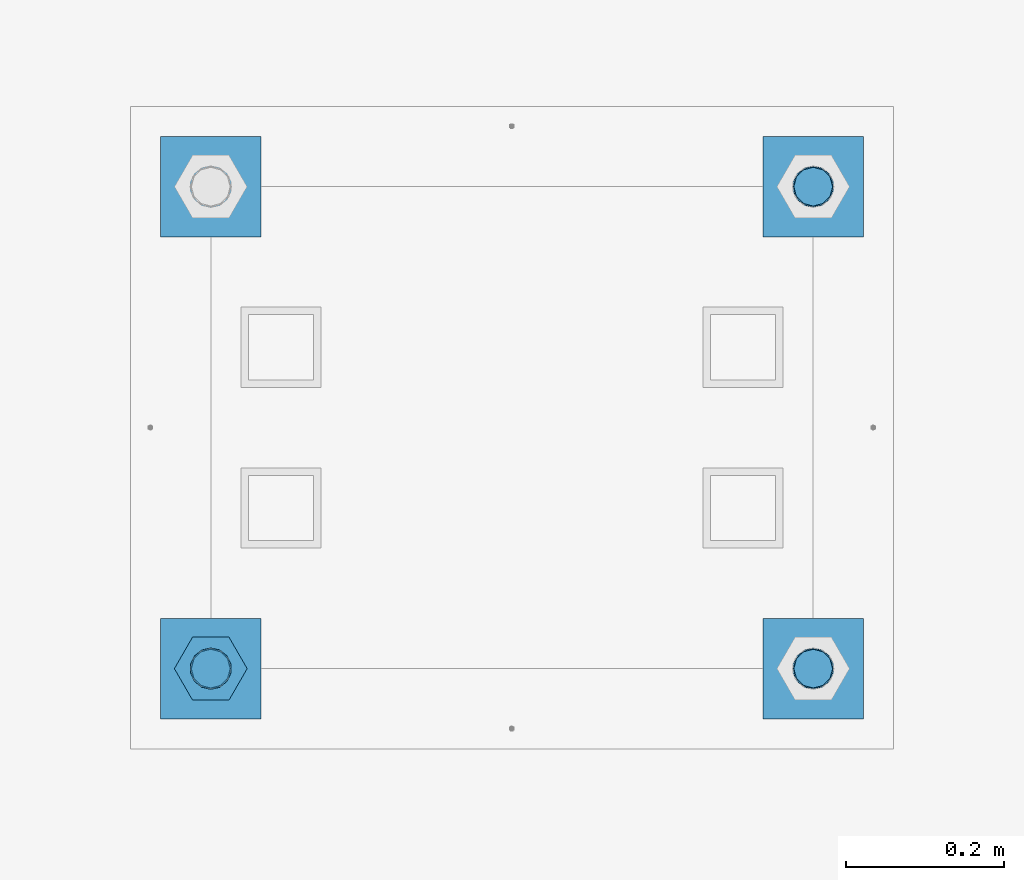
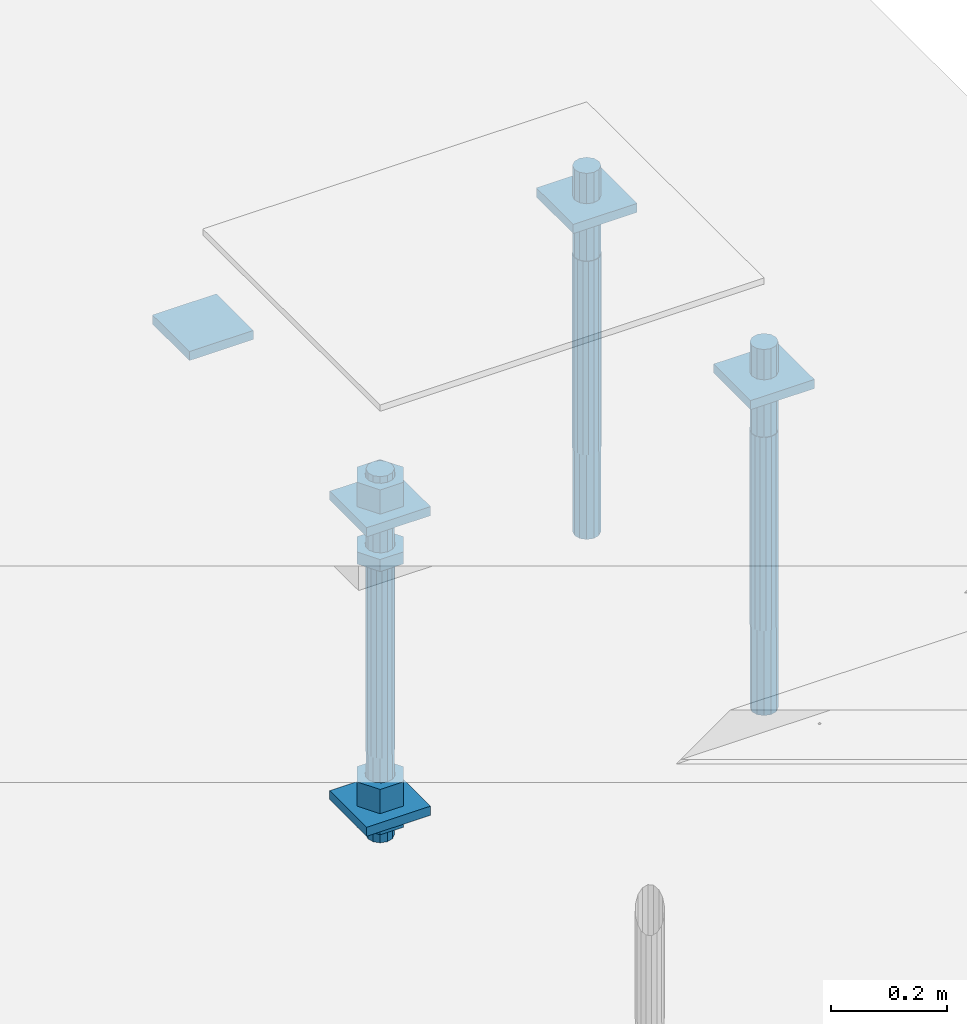
# One storey, part 2634 of 3843: 12 beams, 1 element without a shape of its own.
"""IFC2X3 building model written with IfcOpenShell, lengths in millimetres."""

import ifcopenshell
import ifcopenshell.guid

model = None  # the IFC model being written
_history = None  # IfcOwnerHistory: only IFC2X3 demands one
_inside = {}  # id of a spatial element -> (the spatial element, [elements in it])
_under = {}  # id of a project, library or spatial element -> (it, [spatial elements below it])
_declared = {}  # id of a project -> (the project, [libraries it declares])
_typed = {}  # id of a type object -> (the type object, [elements of that type])
_made_of = {}  # id of a material, layer set ... -> (it, [elements and type objects made of it])


def new_model(schema):
    """Start an empty IFC model of exactly this schema.

    Asked for "IFC4X3", IfcOpenShell would pick the latest addendum, in which some entities
    have other attributes; the version numbers below select the first issue.
    IFC2X3 requires an IfcOwnerHistory on every rooted entity: one is made here for all.
    """
    global model, _history
    if schema == "IFC4X3":
        model = ifcopenshell.file(schema_version=(4, 3, 0, 0))
    else:
        model = ifcopenshell.file(schema=schema)
    _inside.clear()
    _under.clear()
    _declared.clear()
    _typed.clear()
    _made_of.clear()
    _history = None
    if model.schema == "IFC2X3":
        org = make("IfcOrganization", Name="unknown")
        user = make(
            "IfcPersonAndOrganization",
            ThePerson=make("IfcPerson", FamilyName="unknown"),
            TheOrganization=org,
        )
        app = make(
            "IfcApplication",
            ApplicationDeveloper=org,
            Version="unknown",
            ApplicationFullName="unknown",
            ApplicationIdentifier="unknown",
        )
        _history = make(
            "IfcOwnerHistory",
            OwningUser=user,
            OwningApplication=app,
            ChangeAction="ADDED",
            CreationDate=0,
        )
    return model


def make(cls, **values):
    """One entity of the class cls with the attributes given. An attribute that is None is left unset."""
    return model.create_entity(
        cls, **{name: value for name, value in values.items() if value is not None}
    )


def rooted(cls, **values):
    """An entity with a GlobalId (a new one), such as an element, a storey or a relation."""
    return make(cls, GlobalId=ifcopenshell.guid.new(), OwnerHistory=_history, **values)


def si_unit(unit_type, name, prefix=None):
    """IfcSIUnit, for example si_unit("LENGTHUNIT", "METRE", prefix="MILLI")."""
    return make("IfcSIUnit", UnitType=unit_type, Prefix=prefix, Name=name)


def assignment(units):
    """IfcUnitAssignment: the units of a project."""
    return None if units is None else make("IfcUnitAssignment", Units=units)


def point(xyz):
    """IfcCartesianPoint."""
    return None if xyz is None else make("IfcCartesianPoint", Coordinates=xyz)


def direction(xyz):
    """IfcDirection."""
    return None if xyz is None else make("IfcDirection", DirectionRatios=xyz)


def frame(location, z_axis=None, x_axis=None):
    """IfcAxis2Placement3D, a coordinate frame: its origin and axes. An axis left out is left unset."""
    return make(
        "IfcAxis2Placement3D",
        Location=point(location),
        Axis=direction(z_axis),
        RefDirection=direction(x_axis),
    )


def origin_with_axes():
    """The frame at (0, 0, 0) with the z axis (0, 0, 1) and the x axis (1, 0, 0) written out."""
    return frame((0.0, 0.0, 0.0), z_axis=(0.0, 0.0, 1.0), x_axis=(1.0, 0.0, 0.0))


def place(relative_to, where):
    """IfcLocalPlacement: puts the frame where relative to a parent placement (None: the world)."""
    return make(
        "IfcLocalPlacement", PlacementRelTo=relative_to, RelativePlacement=where
    )


def context(
    kind, dimensions, precision=None, world=None, true_north=None, identifier=None
):
    """IfcGeometricRepresentationContext, for example the 3D "Model" context."""
    return make(
        "IfcGeometricRepresentationContext",
        ContextIdentifier=identifier,
        ContextType=kind,
        CoordinateSpaceDimension=dimensions,
        Precision=precision,
        WorldCoordinateSystem=world,
        TrueNorth=true_north,
    )


def subcontext(parent, identifier, kind, view, scale=None):
    """IfcGeometricRepresentationSubContext, for example "Body" below "Model"."""
    return make(
        "IfcGeometricRepresentationSubContext",
        ContextIdentifier=identifier,
        ContextType=kind,
        ParentContext=parent,
        TargetScale=scale,
        TargetView=view,
    )


def project(units=None, contexts=None):
    """IfcProject with its units and contexts."""
    return rooted(
        "IfcProject",
        Name="project",
        RepresentationContexts=contexts,
        UnitsInContext=assignment(units),
    )


def spatial(cls, under=None, at=None, **own):
    """A site, building, storey or space (cls), placed at a placement, below another one or the project."""
    s = rooted(cls, ObjectPlacement=at, **own)
    if under is not None:
        _under.setdefault(under.id(), (under, []))[1].append(s)
    return s


def faces_of(points, faces, orient=None, outer=None):
    """IfcFace entities. A face is a list of loops; a loop is a list of indices into points, from 0.

    orient and outer hold one flag for each loop. By default every Orientation is true, the
    first loop of a face is its IfcFaceOuterBound and the others are IfcFaceBound.
    """
    made = []
    for i, loops in enumerate(faces):
        bounds = []
        for j, loop in enumerate(loops):
            is_outer = j == 0 if outer is None else outer[i][j]
            bounds.append(
                make(
                    "IfcFaceOuterBound" if is_outer else "IfcFaceBound",
                    Bound=make("IfcPolyLoop", Polygon=[points[k] for k in loop]),
                    Orientation=True if orient is None else orient[i][j],
                )
            )
        made.append(make("IfcFace", Bounds=bounds))
    return made


def faceted_brep(points, faces, orient=None, outer=None, voids=None):
    """IfcFacetedBrep: a solid bounded by flat faces; with voids (closed shells), ...WithVoids."""
    shared = [point(p) for p in points]
    hull = make("IfcClosedShell", CfsFaces=faces_of(shared, faces, orient, outer))
    if voids is None:
        return make("IfcFacetedBrep", Outer=hull)
    return make(
        "IfcFacetedBrepWithVoids",
        Outer=hull,
        Voids=[
            make(cls, CfsFaces=faces_of(shared, fs, o, b)) for cls, fs, o, b in voids
        ],
    )


def shape(context_of_items, identifier, shape_type, items):
    """IfcShapeRepresentation: the items that make up one representation, for example the "Body"."""
    return make(
        "IfcShapeRepresentation",
        ContextOfItems=context_of_items,
        RepresentationIdentifier=identifier,
        RepresentationType=shape_type,
        Items=items,
    )


def material(Name=None, Category=None):
    """IfcMaterial."""
    return make("IfcMaterial", Name=Name, Category=Category)


def made_of(thing, what):
    """Note that an element or type object is made of a material, layer set ...; save() writes the relation."""
    if what is not None:
        _made_of.setdefault(what.id(), (what, []))[1].append(thing)
    return thing


def type_object(cls, material=None, **own):
    """A type object (cls), such as IfcWallType, which elements share."""
    return made_of(rooted(cls, **own), material)


def element(
    cls,
    number,
    at=None,
    inside=None,
    cuts=None,
    type_object=None,
    material=None,
    context=None,
    identifier="Body",
    shape_type=None,
    held_by="IfcProductDefinitionShape",
    body=None,
    shapes=None,
    **own,
):
    """One element of the class cls, such as IfcWall. Its Tag is "e" and its number.

    at: its placement. inside: the storey or other place that contains it. cuts: it is an
    opening in that element (IfcRelVoidsElement). A single representation is given by context,
    identifier, shape_type and body (its items); several are given by shapes. held_by: the class
    of the entity that holds the representations. save() writes the other relations.
    """
    e = rooted(cls, Tag="e%d" % number, ObjectPlacement=at, **own)
    if body is not None:
        shapes = [shape(context, identifier, shape_type, body)]
    if shapes is not None:
        e.Representation = make(held_by, Representations=shapes)
    if inside is not None:
        _inside.setdefault(inside.id(), (inside, []))[1].append(e)
    if cuts is not None:
        rooted(
            "IfcRelVoidsElement", RelatingBuildingElement=cuts, RelatedOpeningElement=e
        )
    if type_object is not None:
        _typed.setdefault(type_object.id(), (type_object, []))[1].append(e)
    return made_of(e, material)


def aggregate(whole, parts):
    """IfcRelAggregates: a whole, such as a stair, and the parts it consists of."""
    return rooted("IfcRelAggregates", RelatingObject=whole, RelatedObjects=parts)


def save(model, path):
    """Write the relations noted so far, then the file.

    IfcRelAggregates (storeys below a building ...), IfcRelContainedInSpatialStructure (elements
    in a storey), IfcRelDefinesByType, IfcRelAssociatesMaterial and IfcRelDeclares: one each for
    every whole, place, type object, material and project.
    """
    for whole, parts in _under.values():
        aggregate(whole, parts)
    for where, things in _inside.values():
        rooted(
            "IfcRelContainedInSpatialStructure",
            RelatedElements=things,
            RelatingStructure=where,
        )
    for kind, things in _typed.values():
        rooted("IfcRelDefinesByType", RelatedObjects=things, RelatingType=kind)
    for what, things in _made_of.values():
        rooted("IfcRelAssociatesMaterial", RelatedObjects=things, RelatingMaterial=what)
    for by, libraries in _declared.values():
        rooted("IfcRelDeclares", RelatingContext=by, RelatedDefinitions=libraries)
    model.write(path)


model = new_model("IFC2X3")

# Units and contexts
model_context = context("Model", 3, precision=1e-05, world=origin_with_axes())
body_context = subcontext(model_context, "Body", "Model", "MODEL_VIEW")
ifc_project = project(units=[si_unit("LENGTHUNIT", "METRE", prefix="MILLI"), si_unit("AREAUNIT", "SQUARE_METRE"), si_unit("VOLUMEUNIT", "CUBIC_METRE"), si_unit("MASSUNIT", "GRAM", prefix="KILO"), si_unit("TIMEUNIT", "SECOND"), si_unit("PLANEANGLEUNIT", "RADIAN"), si_unit("SOLIDANGLEUNIT", "STERADIAN"), si_unit("THERMODYNAMICTEMPERATUREUNIT", "DEGREE_CELSIUS"), si_unit("LUMINOUSINTENSITYUNIT", "LUMEN")], contexts=[model_context])

# Site, building, storey
site_placement = place(None, origin_with_axes())
site = spatial("IfcSite", under=ifc_project, at=site_placement, CompositionType="ELEMENT")
building_placement = place(site_placement, origin_with_axes())
building = spatial("IfcBuilding", under=site, at=building_placement, Name="Undefined", CompositionType="ELEMENT")
storey_placement = place(building_placement, origin_with_axes())
storey = spatial("IfcBuildingStorey", under=building, at=storey_placement, Name="Undefined", CompositionType="ELEMENT", Elevation=0.0)

# Assembly, beams
assembly_placement = place(storey_placement, origin_with_axes())
assembly = element("IfcElementAssembly", 1, at=assembly_placement, inside=storey, Name="TEMPLATE", AssemblyPlace="NOTDEFINED", PredefinedType="RIGID_FRAME")
ifc_material_1 = material(Name="STEEL/A572-50")
beam_type_1 = type_object("IfcBeamType", PredefinedType="NOTDEFINED")
beam_1_placement = place(assembly_placement, frame((118465.6, 2819.40000152587, 29873.575), z_axis=(1.0, 0.0, 0.0), x_axis=(0.0, 1.0, 0.0)))
beam_1 = element("IfcBeam", 2, at=beam_1_placement, type_object=beam_type_1, material=ifc_material_1, Name="WASHER_PLATE", context=body_context, shape_type="Brep", body=[
    faceted_brep([(0.0, 9.52500000000146, -63.5), (0.0, 9.52500000000146, 63.5), (127.0, 9.52500000000146, 63.5), (127.0, 9.52500000000146, -63.5), (0.0, -9.52500000000146, 63.5), (127.0, -9.52500000000146, 63.5), (0.0, -9.52500000000146, -63.5), (127.0, -9.52500000000146, -63.5)], [[[0, 1, 2, 3]], [[1, 4, 5, 2]], [[4, 6, 7, 5]], [[6, 0, 3, 7]], [[5, 7, 3, 2]], [[6, 4, 1, 0]]]),
])
beam_2_placement = place(assembly_placement, frame((119227.6, 2819.40000152587, 29873.575), z_axis=(1.0, 0.0, 0.0), x_axis=(0.0, 1.0, 0.0)))
beam_2 = element("IfcBeam", 3, at=beam_2_placement, type_object=beam_type_1, material=ifc_material_1, Name="WASHER_PLATE", context=body_context, shape_type="Brep", body=[
    faceted_brep([(0.0, 9.52500000000146, -63.5), (0.0, 9.52500000000146, 63.5), (127.0, 9.52500000000146, 63.5), (127.0, 9.52500000000146, -63.5), (0.0, -9.52500000000146, 63.5), (127.0, -9.52500000000146, 63.5), (0.0, -9.52500000000146, -63.5), (127.0, -9.52500000000146, -63.5)], [[[0, 1, 2, 3]], [[1, 4, 5, 2]], [[4, 6, 7, 5]], [[6, 0, 3, 7]], [[5, 7, 3, 2]], [[6, 4, 1, 0]]]),
])
beam_3_placement = place(assembly_placement, frame((118465.6, 3429.00000152587, 29873.575), z_axis=(1.0, 0.0, 0.0), x_axis=(0.0, 1.0, 0.0)))
beam_3 = element("IfcBeam", 4, at=beam_3_placement, type_object=beam_type_1, material=ifc_material_1, Name="WASHER_PLATE", context=body_context, shape_type="Brep", body=[
    faceted_brep([(0.0, 9.52500000000146, -63.5), (0.0, 9.52500000000146, 63.5), (127.0, 9.52500000000146, 63.5), (127.0, 9.52500000000146, -63.5), (0.0, -9.52500000000146, 63.5), (127.0, -9.52500000000146, 63.5), (0.0, -9.52500000000146, -63.5), (127.0, -9.52500000000146, -63.5)], [[[0, 1, 2, 3]], [[1, 4, 5, 2]], [[4, 6, 7, 5]], [[6, 0, 3, 7]], [[5, 7, 3, 2]], [[6, 4, 1, 0]]]),
])
beam_4_placement = place(assembly_placement, frame((119227.6, 3429.00000152587, 29873.575), z_axis=(1.0, 0.0, 0.0), x_axis=(0.0, 1.0, 0.0)))
beam_4 = element("IfcBeam", 5, at=beam_4_placement, type_object=beam_type_1, material=ifc_material_1, Name="WASHER_PLATE", context=body_context, shape_type="Brep", body=[
    faceted_brep([(0.0, 9.52500000000146, -63.5), (0.0, 9.52500000000146, 63.5), (127.0, 9.52500000000146, 63.5), (127.0, 9.52500000000146, -63.5), (0.0, -9.52500000000146, 63.5), (127.0, -9.52500000000146, 63.5), (0.0, -9.52500000000146, -63.5), (127.0, -9.52500000000146, -63.5)], [[[0, 1, 2, 3]], [[1, 4, 5, 2]], [[4, 6, 7, 5]], [[6, 0, 3, 7]], [[5, 7, 3, 2]], [[6, 4, 1, 0]]]),
])
beam_5_placement = place(assembly_placement, frame((118465.6, 2819.40000152587, 29244.925), z_axis=(1.0, 0.0, 0.0), x_axis=(0.0, 1.0, 0.0)))
beam_5 = element("IfcBeam", 6, at=beam_5_placement, type_object=beam_type_1, material=ifc_material_1, Name="WASHER_PLATE", context=body_context, shape_type="Brep", body=[
    faceted_brep([(0.0, 9.52500000000146, -63.5), (0.0, 9.52500000000146, 63.5), (127.0, 9.52500000000146, 63.5), (127.0, 9.52500000000146, -63.5), (0.0, -9.52500000000146, 63.5), (127.0, -9.52500000000146, 63.5), (0.0, -9.52500000000146, -63.5), (127.0, -9.52500000000146, -63.5)], [[[0, 1, 2, 3]], [[1, 4, 5, 2]], [[4, 6, 7, 5]], [[6, 0, 3, 7]], [[5, 7, 3, 2]], [[6, 4, 1, 0]]]),
])
ifc_material_2 = material(Name="STEEL/A36")
beam_type_2 = type_object("IfcBeamType", Name="2_HALF_NUT", PredefinedType="NOTDEFINED")
beam_6_placement = place(assembly_placement, frame((118465.6, 2882.90000152587, 29787.85), z_axis=(0.0, 1.0, 0.0), x_axis=(0.0, 0.0, -1.0)))
beam_6 = element("IfcBeam", 7, at=beam_6_placement, type_object=beam_type_2, material=ifc_material_2, Name="NUT", ObjectType="2_HALF_NUT", context=body_context, shape_type="Brep", body=[
    faceted_brep([(0.0, -46.0369987487793, 0.0), (0.0, -23.0184993743896, -39.869213104248), (25.4000000000015, -23.0184993743896, -39.869213104248), (25.4000000000015, -46.0369987487793, 0.0), (0.0, 23.0184993743896, -39.869213104248), (25.4000000000015, 23.0184993743896, -39.869213104248), (0.0, 46.0369987487793, 0.0), (25.4000000000015, 46.0369987487793, 0.0), (0.0, 23.0184993743896, 39.869213104248), (25.4000000000015, 23.0184993743896, 39.869213104248), (0.0, -23.0184993743896, 39.869213104248), (25.4000000000015, -23.0184993743896, 39.869213104248), (0.0, 0.0, 26.1940002441406), (0.0, 11.3650617044477, 23.5999013092805), (25.4000000000015, 11.3650617044477, 23.5999013092805), (25.4000000000015, 0.0, 26.1940002441406), (0.0, 20.4791109456419, 16.3316083006721), (25.4000000000015, 20.4791109456419, 16.3316083006721), (0.0, 25.5370200498292, 5.82867859874386), (25.4000000000015, 25.5370200498292, 5.82867859874386), (0.0, 25.5370200498292, -5.82867859874386), (25.4000000000015, 25.5370200498292, -5.82867859874386), (0.0, 20.4791109456419, -16.3316083006721), (25.4000000000015, 20.4791109456419, -16.3316083006721), (0.0, 11.3650617044477, -23.5999013092805), (25.4000000000015, 11.3650617044477, -23.5999013092805), (0.0, 0.0, -26.1940002441406), (25.4000000000015, 0.0, -26.1940002441406), (0.0, -11.3650617044477, -23.5999013092805), (25.4000000000015, -11.3650617044477, -23.5999013092805), (0.0, -20.4791109456419, -16.3316083006721), (25.4000000000015, -20.4791109456419, -16.3316083006721), (0.0, -25.5370200498292, -5.82867859874386), (25.4000000000015, -25.5370200498292, -5.82867859874386), (0.0, -25.5370200498292, 5.82867859874386), (25.4000000000015, -25.5370200498292, 5.82867859874386), (0.0, -20.4791109456419, 16.3316083006721), (25.4000000000015, -20.4791109456419, 16.3316083006721), (0.0, -11.3650617044477, 23.5999013092805), (25.4000000000015, -11.3650617044477, 23.5999013092805)], [[[0, 1, 2, 3]], [[1, 4, 5, 2]], [[4, 6, 7, 5]], [[6, 8, 9, 7]], [[8, 10, 11, 9]], [[10, 0, 3, 11]], [[12, 13, 14, 15]], [[13, 16, 17, 14]], [[16, 18, 19, 17]], [[18, 20, 21, 19]], [[20, 22, 23, 21]], [[22, 24, 25, 23]], [[24, 26, 27, 25]], [[26, 28, 29, 27]], [[28, 30, 31, 29]], [[30, 32, 33, 31]], [[32, 34, 35, 33]], [[34, 36, 37, 35]], [[36, 38, 39, 37]], [[38, 12, 15, 39]], [[5, 7, 9, 11, 3, 2], [17, 19, 21, 23, 25, 27, 29, 31, 33, 35, 37, 39, 15, 14]], [[10, 8, 6, 4, 1, 0], [38, 36, 34, 32, 30, 28, 26, 24, 22, 20, 18, 16, 13, 12]]]),
])
beam_7_placement = place(assembly_placement, frame((118465.6, 2882.90000152587, 29235.4), z_axis=(0.0, 1.0, 0.0), x_axis=(0.0, 0.0, -1.0)))
beam_7 = element("IfcBeam", 8, at=beam_7_placement, type_object=beam_type_2, material=ifc_material_2, Name="NUT", ObjectType="2_HALF_NUT", context=body_context, shape_type="Brep", body=[
    faceted_brep([(0.0, -46.0369987487793, 0.0), (0.0, -23.0184993743896, -39.869213104248), (25.4000000000015, -23.0184993743896, -39.869213104248), (25.4000000000015, -46.0369987487793, 0.0), (0.0, 23.0184993743896, -39.869213104248), (25.4000000000015, 23.0184993743896, -39.869213104248), (0.0, 46.0369987487793, 0.0), (25.4000000000015, 46.0369987487793, 0.0), (0.0, 23.0184993743896, 39.869213104248), (25.4000000000015, 23.0184993743896, 39.869213104248), (0.0, -23.0184993743896, 39.869213104248), (25.4000000000015, -23.0184993743896, 39.869213104248), (0.0, 0.0, 26.1940002441406), (0.0, 11.3650617044477, 23.5999013092805), (25.4000000000015, 11.3650617044477, 23.5999013092805), (25.4000000000015, 0.0, 26.1940002441406), (0.0, 20.4791109456419, 16.3316083006721), (25.4000000000015, 20.4791109456419, 16.3316083006721), (0.0, 25.5370200498292, 5.82867859874386), (25.4000000000015, 25.5370200498292, 5.82867859874386), (0.0, 25.5370200498292, -5.82867859874386), (25.4000000000015, 25.5370200498292, -5.82867859874386), (0.0, 20.4791109456419, -16.3316083006721), (25.4000000000015, 20.4791109456419, -16.3316083006721), (0.0, 11.3650617044477, -23.5999013092805), (25.4000000000015, 11.3650617044477, -23.5999013092805), (0.0, 0.0, -26.1940002441406), (25.4000000000015, 0.0, -26.1940002441406), (0.0, -11.3650617044477, -23.5999013092805), (25.4000000000015, -11.3650617044477, -23.5999013092805), (0.0, -20.4791109456419, -16.3316083006721), (25.4000000000015, -20.4791109456419, -16.3316083006721), (0.0, -25.5370200498292, -5.82867859874386), (25.4000000000015, -25.5370200498292, -5.82867859874386), (0.0, -25.5370200498292, 5.82867859874386), (25.4000000000015, -25.5370200498292, 5.82867859874386), (0.0, -20.4791109456419, 16.3316083006721), (25.4000000000015, -20.4791109456419, 16.3316083006721), (0.0, -11.3650617044477, 23.5999013092805), (25.4000000000015, -11.3650617044477, 23.5999013092805)], [[[0, 1, 2, 3]], [[1, 4, 5, 2]], [[4, 6, 7, 5]], [[6, 8, 9, 7]], [[8, 10, 11, 9]], [[10, 0, 3, 11]], [[12, 13, 14, 15]], [[13, 16, 17, 14]], [[16, 18, 19, 17]], [[18, 20, 21, 19]], [[20, 22, 23, 21]], [[22, 24, 25, 23]], [[24, 26, 27, 25]], [[26, 28, 29, 27]], [[28, 30, 31, 29]], [[30, 32, 33, 31]], [[32, 34, 35, 33]], [[34, 36, 37, 35]], [[36, 38, 39, 37]], [[38, 12, 15, 39]], [[5, 7, 9, 11, 3, 2], [17, 19, 21, 23, 25, 27, 29, 31, 33, 35, 37, 39, 15, 14]], [[10, 8, 6, 4, 1, 0], [38, 36, 34, 32, 30, 28, 26, 24, 22, 20, 18, 16, 13, 12]]]),
])
beam_type_3 = type_object("IfcBeamType", Name="2_HEAVY_HEX_NUT", PredefinedType="NOTDEFINED")
beam_8_placement = place(assembly_placement, frame((118465.6, 2882.90000152587, 29933.9), z_axis=(0.0, 1.0, 0.0), x_axis=(0.0, 0.0, -1.0)))
beam_8 = element("IfcBeam", 9, at=beam_8_placement, type_object=beam_type_3, material=ifc_material_2, Name="NUT", ObjectType="2_HEAVY_HEX_NUT", context=body_context, shape_type="Brep", body=[
    faceted_brep([(0.0, -46.0369987487793, 0.0), (0.0, -23.0184993743896, -39.869213104248), (50.7999999999993, -23.0184993743896, -39.869213104248), (50.7999999999993, -46.0369987487793, 0.0), (0.0, 23.0184993743896, -39.869213104248), (50.7999999999993, 23.0184993743896, -39.869213104248), (0.0, 46.0369987487793, 0.0), (50.7999999999993, 46.0369987487793, 0.0), (0.0, 23.0184993743896, 39.869213104248), (50.7999999999993, 23.0184993743896, 39.869213104248), (0.0, -23.0184993743896, 39.869213104248), (50.7999999999993, -23.0184993743896, 39.869213104248), (0.0, 0.0, 26.1940002441406), (0.0, 11.3650617044477, 23.5999013092805), (50.7999999999993, 11.3650617044477, 23.5999013092805), (50.7999999999993, 0.0, 26.1940002441406), (0.0, 20.4791109456419, 16.3316083006721), (50.7999999999993, 20.4791109456419, 16.3316083006721), (0.0, 25.5370200498292, 5.82867859874386), (50.7999999999993, 25.5370200498292, 5.82867859874386), (0.0, 25.5370200498292, -5.82867859874386), (50.7999999999993, 25.5370200498292, -5.82867859874386), (0.0, 20.4791109456419, -16.3316083006721), (50.7999999999993, 20.4791109456419, -16.3316083006721), (0.0, 11.3650617044477, -23.5999013092805), (50.7999999999993, 11.3650617044477, -23.5999013092805), (0.0, 0.0, -26.1940002441406), (50.7999999999993, 0.0, -26.1940002441406), (0.0, -11.3650617044477, -23.5999013092805), (50.7999999999993, -11.3650617044477, -23.5999013092805), (0.0, -20.4791109456419, -16.3316083006721), (50.7999999999993, -20.4791109456419, -16.3316083006721), (0.0, -25.5370200498292, -5.82867859874386), (50.7999999999993, -25.5370200498292, -5.82867859874386), (0.0, -25.5370200498292, 5.82867859874386), (50.7999999999993, -25.5370200498292, 5.82867859874386), (0.0, -20.4791109456419, 16.3316083006721), (50.7999999999993, -20.4791109456419, 16.3316083006721), (0.0, -11.3650617044477, 23.5999013092805), (50.7999999999993, -11.3650617044477, 23.5999013092805)], [[[0, 1, 2, 3]], [[1, 4, 5, 2]], [[4, 6, 7, 5]], [[6, 8, 9, 7]], [[8, 10, 11, 9]], [[10, 0, 3, 11]], [[12, 13, 14, 15]], [[13, 16, 17, 14]], [[16, 18, 19, 17]], [[18, 20, 21, 19]], [[20, 22, 23, 21]], [[22, 24, 25, 23]], [[24, 26, 27, 25]], [[26, 28, 29, 27]], [[28, 30, 31, 29]], [[30, 32, 33, 31]], [[32, 34, 35, 33]], [[34, 36, 37, 35]], [[36, 38, 39, 37]], [[38, 12, 15, 39]], [[5, 7, 9, 11, 3, 2], [17, 19, 21, 23, 25, 27, 29, 31, 33, 35, 37, 39, 15, 14]], [[10, 8, 6, 4, 1, 0], [38, 36, 34, 32, 30, 28, 26, 24, 22, 20, 18, 16, 13, 12]]]),
])
beam_9_placement = place(assembly_placement, frame((118465.6, 2882.90000152587, 29305.25), z_axis=(0.0, 1.0, 0.0), x_axis=(0.0, 0.0, -1.0)))
beam_9 = element("IfcBeam", 10, at=beam_9_placement, type_object=beam_type_3, material=ifc_material_2, Name="NUT", ObjectType="2_HEAVY_HEX_NUT", context=body_context, shape_type="Brep", body=[
    faceted_brep([(0.0, -46.0369987487793, 0.0), (0.0, -23.0184993743896, -39.869213104248), (50.7999999999993, -23.0184993743896, -39.869213104248), (50.7999999999993, -46.0369987487793, 0.0), (0.0, 23.0184993743896, -39.869213104248), (50.7999999999993, 23.0184993743896, -39.869213104248), (0.0, 46.0369987487793, 0.0), (50.7999999999993, 46.0369987487793, 0.0), (0.0, 23.0184993743896, 39.869213104248), (50.7999999999993, 23.0184993743896, 39.869213104248), (0.0, -23.0184993743896, 39.869213104248), (50.7999999999993, -23.0184993743896, 39.869213104248), (0.0, 0.0, 26.1940002441406), (0.0, 11.3650617044477, 23.5999013092805), (50.7999999999993, 11.3650617044477, 23.5999013092805), (50.7999999999993, 0.0, 26.1940002441406), (0.0, 20.4791109456419, 16.3316083006721), (50.7999999999993, 20.4791109456419, 16.3316083006721), (0.0, 25.5370200498292, 5.82867859874386), (50.7999999999993, 25.5370200498292, 5.82867859874386), (0.0, 25.5370200498292, -5.82867859874386), (50.7999999999993, 25.5370200498292, -5.82867859874386), (0.0, 20.4791109456419, -16.3316083006721), (50.7999999999993, 20.4791109456419, -16.3316083006721), (0.0, 11.3650617044477, -23.5999013092805), (50.7999999999993, 11.3650617044477, -23.5999013092805), (0.0, 0.0, -26.1940002441406), (50.7999999999993, 0.0, -26.1940002441406), (0.0, -11.3650617044477, -23.5999013092805), (50.7999999999993, -11.3650617044477, -23.5999013092805), (0.0, -20.4791109456419, -16.3316083006721), (50.7999999999993, -20.4791109456419, -16.3316083006721), (0.0, -25.5370200498292, -5.82867859874386), (50.7999999999993, -25.5370200498292, -5.82867859874386), (0.0, -25.5370200498292, 5.82867859874386), (50.7999999999993, -25.5370200498292, 5.82867859874386), (0.0, -20.4791109456419, 16.3316083006721), (50.7999999999993, -20.4791109456419, 16.3316083006721), (0.0, -11.3650617044477, 23.5999013092805), (50.7999999999993, -11.3650617044477, 23.5999013092805)], [[[0, 1, 2, 3]], [[1, 4, 5, 2]], [[4, 6, 7, 5]], [[6, 8, 9, 7]], [[8, 10, 11, 9]], [[10, 0, 3, 11]], [[12, 13, 14, 15]], [[13, 16, 17, 14]], [[16, 18, 19, 17]], [[18, 20, 21, 19]], [[20, 22, 23, 21]], [[22, 24, 25, 23]], [[24, 26, 27, 25]], [[26, 28, 29, 27]], [[28, 30, 31, 29]], [[30, 32, 33, 31]], [[32, 34, 35, 33]], [[34, 36, 37, 35]], [[36, 38, 39, 37]], [[38, 12, 15, 39]], [[5, 7, 9, 11, 3, 2], [17, 19, 21, 23, 25, 27, 29, 31, 33, 35, 37, 39, 15, 14]], [[10, 8, 6, 4, 1, 0], [38, 36, 34, 32, 30, 28, 26, 24, 22, 20, 18, 16, 13, 12]]]),
])
ifc_material_3 = material()
beam_type_4 = type_object("IfcBeamType", PredefinedType="NOTDEFINED")
beam_10_placement = place(assembly_placement, frame((119227.600001526, 3492.49999999999, 29762.45), z_axis=(1.0, 0.0, 0.0), x_axis=(0.0, 0.0, -1.0)))
beam_10 = element("IfcBeam", 11, at=beam_10_placement, type_object=beam_type_4, material=ifc_material_3, Name="ANCHOR_ROD", context=body_context, shape_type="Brep", body=[
    faceted_brep([(0.0, -23.4665401257807, -9.72015918207035), (0.0, -17.9605122421344, -17.9605122421417), (406.399999999998, -17.9605122421344, -17.9605122421417), (406.399999999998, -23.4665401257807, -9.72015918207035), (0.0, -9.72015918207762, -23.466540125788), (406.399999999998, -9.72015918207762, -23.466540125788), (0.0, 0.0, -25.4000000000015), (406.399999999998, 0.0, -25.4000000000015), (0.0, 9.72015918207762, -23.466540125788), (406.399999999998, 9.72015918207762, -23.466540125788), (0.0, 17.9605122421344, -17.9605122421417), (406.399999999998, 17.9605122421344, -17.9605122421417), (0.0, 23.4665401257807, -9.72015918207035), (406.399999999998, 23.4665401257807, -9.72015918207035), (0.0, 25.3999996185303, 0.0), (406.399999999998, 25.3999999999942, 0.0), (0.0, 23.4665401257807, 9.72015918207035), (406.399999999998, 23.4665401257807, 9.72015918207035), (0.0, 17.9605122421344, 17.9605122421417), (406.399999999998, 17.9605122421344, 17.9605122421417), (0.0, 9.72015918207762, 23.466540125788), (406.399999999998, 9.72015918207762, 23.466540125788), (0.0, 0.0, 25.4000000000015), (406.399999999998, 0.0, 25.4000000000015), (0.0, -9.72015918207762, 23.466540125788), (406.399999999998, -9.72015918207762, 23.466540125788), (0.0, -17.9605122421344, 17.9605122421417), (406.399999999998, -17.9605122421344, 17.9605122421417), (0.0, -23.4665401257807, 9.72015918207035), (406.399999999998, -23.4665401257807, 9.72015918207035), (0.0, -25.3999996185303, 0.0), (406.399999999998, -25.3999999999942, 0.0), (584.200000000001, -12.2499999999854, -21.2176223927163), (584.200000000001, 1.45519152283669e-11, -24.5), (584.200000000001, 12.2500000000146, -21.2176223927163), (584.200000000001, 21.2176223927381, -12.25), (584.200000000001, 24.5000000000146, 0.0), (584.200000000001, 21.2176223927381, 12.25), (584.200000000001, 12.2500000000146, 21.2176223927163), (584.200000000001, 1.45519152283669e-11, 24.5), (584.200000000001, -12.2499999999854, 21.2176223927163), (584.200000000001, -21.217622392709, 12.25), (584.200000000001, -24.4999999999854, 0.0), (584.200000000001, -21.217622392709, -12.25), (406.399999999998, -24.4999999999854, 0.0), (406.399999999998, -21.217622392709, -12.25), (406.399999999998, -12.2499999999854, -21.2176223927163), (406.399999999998, 1.45519152283669e-11, -24.5), (406.399999999998, 12.2500000000146, -21.2176223927163), (406.399999999998, 21.2176223927381, -12.25), (406.399999999998, 24.5000000000146, 0.0), (406.399999999998, 21.2176223927381, 12.25), (406.399999999998, 12.2500000000146, 21.2176223927163), (406.399999999998, 1.45519152283669e-11, 24.5), (406.399999999998, -12.2499999999854, 21.2176223927163), (406.399999999998, -21.217622392709, 12.25), (0.0, 12.2500000000146, 21.2176223927163), (0.0, 1.45519152283669e-11, 24.5), (0.0, -12.2499999999854, 21.2176223927163), (0.0, -21.217622392709, 12.25), (0.0, -24.4999999999854, 0.0), (0.0, -21.217622392709, -12.25), (0.0, -12.2499999999854, -21.2176223927163), (0.0, 1.45519152283669e-11, -24.5), (0.0, 12.2500000000146, -21.2176223927163), (0.0, 21.2176223927381, -12.25), (0.0, 24.5000000000146, 0.0), (0.0, 21.2176223927381, 12.25), (-184.150000000001, -21.217622392709, 12.25), (-184.150000000001, -12.2499999999854, 21.2176223927163), (-184.150000000001, 1.45519152283669e-11, 24.5), (-184.150000000001, 12.2500000000146, 21.2176223927163), (-184.150000000001, 21.2176223927381, 12.25), (-184.150000000001, 24.5000000000146, 0.0), (-184.150000000001, 21.2176223927381, -12.25), (-184.150000000001, 12.2500000000146, -21.2176223927163), (-184.150000000001, 1.45519152283669e-11, -24.5), (-184.150000000001, -12.2499999999854, -21.2176223927163), (-184.150000000001, -21.217622392709, -12.25), (-184.150000000001, -24.4999999999854, 0.0)], [[[0, 1, 2, 3]], [[1, 4, 5, 2]], [[4, 6, 7, 5]], [[6, 8, 9, 7]], [[8, 10, 11, 9]], [[10, 12, 13, 11]], [[12, 14, 15, 13]], [[14, 16, 17, 15]], [[16, 18, 19, 17]], [[18, 20, 21, 19]], [[20, 22, 23, 21]], [[22, 24, 25, 23]], [[24, 26, 27, 25]], [[26, 28, 29, 27]], [[28, 30, 31, 29]], [[32, 33, 34, 35, 36, 37, 38, 39, 40, 41, 42, 43]], [[43, 42, 44, 45]], [[32, 43, 45, 46]], [[33, 32, 46, 47]], [[34, 33, 47, 48]], [[35, 34, 48, 49]], [[36, 35, 49, 50]], [[37, 36, 50, 51]], [[38, 37, 51, 52]], [[39, 38, 52, 53]], [[40, 39, 53, 54]], [[41, 40, 54, 55]], [[42, 41, 55, 44]], [[2, 5, 7, 9, 11, 13, 15, 17, 19, 21, 23, 25, 27, 29, 31, 3], [54, 53, 52, 51, 50, 49, 48, 47, 46, 45, 44, 55]], [[30, 0, 3, 31]], [[28, 26, 24, 22, 20, 18, 16, 14, 12, 10, 8, 6, 4, 1, 0, 30], [56, 57, 58, 59, 60, 61, 62, 63, 64, 65, 66, 67]], [[68, 69, 70, 71, 72, 73, 74, 75, 76, 77, 78, 79]], [[71, 70, 57, 56]], [[72, 71, 56, 67]], [[73, 72, 67, 66]], [[74, 73, 66, 65]], [[75, 74, 65, 64]], [[76, 75, 64, 63]], [[77, 76, 63, 62]], [[78, 77, 62, 61]], [[79, 78, 61, 60]], [[68, 79, 60, 59]], [[69, 68, 59, 58]], [[70, 69, 58, 57]]]),
])
beam_11_placement = place(assembly_placement, frame((118465.600001526, 2882.89999999998, 29762.45), z_axis=(1.0, 0.0, 0.0), x_axis=(0.0, 0.0, -1.0)))
beam_11 = element("IfcBeam", 12, at=beam_11_placement, type_object=beam_type_4, material=ifc_material_3, Name="ANCHOR_ROD", context=body_context, shape_type="Brep", body=[
    faceted_brep([(0.0, -23.4665401257807, -9.72015918207035), (0.0, -17.9605122421344, -17.9605122421417), (406.399999999998, -17.9605122421344, -17.9605122421417), (406.399999999998, -23.4665401257807, -9.72015918207035), (0.0, -9.72015918207762, -23.466540125788), (406.399999999998, -9.72015918207762, -23.466540125788), (0.0, 0.0, -25.4000000000015), (406.399999999998, 0.0, -25.4000000000015), (0.0, 9.72015918207762, -23.466540125788), (406.399999999998, 9.72015918207762, -23.466540125788), (0.0, 17.9605122421344, -17.9605122421417), (406.399999999998, 17.9605122421344, -17.9605122421417), (0.0, 23.4665401257807, -9.72015918207035), (406.399999999998, 23.4665401257807, -9.72015918207035), (0.0, 25.3999996185303, 0.0), (406.399999999998, 25.3999999999942, 0.0), (0.0, 23.4665401257807, 9.72015918207035), (406.399999999998, 23.4665401257807, 9.72015918207035), (0.0, 17.9605122421344, 17.9605122421417), (406.399999999998, 17.9605122421344, 17.9605122421417), (0.0, 9.72015918207762, 23.466540125788), (406.399999999998, 9.72015918207762, 23.466540125788), (0.0, 0.0, 25.4000000000015), (406.399999999998, 0.0, 25.4000000000015), (0.0, -9.72015918207762, 23.466540125788), (406.399999999998, -9.72015918207762, 23.466540125788), (0.0, -17.9605122421344, 17.9605122421417), (406.399999999998, -17.9605122421344, 17.9605122421417), (0.0, -23.4665401257807, 9.72015918207035), (406.399999999998, -23.4665401257807, 9.72015918207035), (0.0, -25.3999996185303, 0.0), (406.399999999998, -25.3999999999942, 0.0), (584.200000000001, -12.2499999999854, -21.2176223927163), (584.200000000001, 1.45519152283669e-11, -24.5), (584.200000000001, 12.2500000000146, -21.2176223927163), (584.200000000001, 21.2176223927381, -12.25), (584.200000000001, 24.5000000000146, 0.0), (584.200000000001, 21.2176223927381, 12.25), (584.200000000001, 12.2500000000146, 21.2176223927163), (584.200000000001, 1.45519152283669e-11, 24.5), (584.200000000001, -12.2499999999854, 21.2176223927163), (584.200000000001, -21.217622392709, 12.25), (584.200000000001, -24.4999999999854, 0.0), (584.200000000001, -21.217622392709, -12.25), (406.399999999998, -24.4999999999854, 0.0), (406.399999999998, -21.217622392709, -12.25), (406.399999999998, -12.2499999999854, -21.2176223927163), (406.399999999998, 1.45519152283669e-11, -24.5), (406.399999999998, 12.2500000000146, -21.2176223927163), (406.399999999998, 21.2176223927381, -12.25), (406.399999999998, 24.5000000000146, 0.0), (406.399999999998, 21.2176223927381, 12.25), (406.399999999998, 12.2500000000146, 21.2176223927163), (406.399999999998, 1.45519152283669e-11, 24.5), (406.399999999998, -12.2499999999854, 21.2176223927163), (406.399999999998, -21.217622392709, 12.25), (0.0, 12.2500000000146, 21.2176223927163), (0.0, 1.45519152283669e-11, 24.5), (0.0, -12.2499999999854, 21.2176223927163), (0.0, -21.217622392709, 12.25), (0.0, -24.4999999999854, 0.0), (0.0, -21.217622392709, -12.25), (0.0, -12.2499999999854, -21.2176223927163), (0.0, 1.45519152283669e-11, -24.5), (0.0, 12.2500000000146, -21.2176223927163), (0.0, 21.2176223927381, -12.25), (0.0, 24.5000000000146, 0.0), (0.0, 21.2176223927381, 12.25), (-184.150000000001, -21.217622392709, 12.25), (-184.150000000001, -12.2499999999854, 21.2176223927163), (-184.150000000001, 1.45519152283669e-11, 24.5), (-184.150000000001, 12.2500000000146, 21.2176223927163), (-184.150000000001, 21.2176223927381, 12.25), (-184.150000000001, 24.5000000000146, 0.0), (-184.150000000001, 21.2176223927381, -12.25), (-184.150000000001, 12.2500000000146, -21.2176223927163), (-184.150000000001, 1.45519152283669e-11, -24.5), (-184.150000000001, -12.2499999999854, -21.2176223927163), (-184.150000000001, -21.217622392709, -12.25), (-184.150000000001, -24.4999999999854, 0.0)], [[[0, 1, 2, 3]], [[1, 4, 5, 2]], [[4, 6, 7, 5]], [[6, 8, 9, 7]], [[8, 10, 11, 9]], [[10, 12, 13, 11]], [[12, 14, 15, 13]], [[14, 16, 17, 15]], [[16, 18, 19, 17]], [[18, 20, 21, 19]], [[20, 22, 23, 21]], [[22, 24, 25, 23]], [[24, 26, 27, 25]], [[26, 28, 29, 27]], [[28, 30, 31, 29]], [[32, 33, 34, 35, 36, 37, 38, 39, 40, 41, 42, 43]], [[43, 42, 44, 45]], [[32, 43, 45, 46]], [[33, 32, 46, 47]], [[34, 33, 47, 48]], [[35, 34, 48, 49]], [[36, 35, 49, 50]], [[37, 36, 50, 51]], [[38, 37, 51, 52]], [[39, 38, 52, 53]], [[40, 39, 53, 54]], [[41, 40, 54, 55]], [[42, 41, 55, 44]], [[2, 5, 7, 9, 11, 13, 15, 17, 19, 21, 23, 25, 27, 29, 31, 3], [54, 53, 52, 51, 50, 49, 48, 47, 46, 45, 44, 55]], [[30, 0, 3, 31]], [[28, 26, 24, 22, 20, 18, 16, 14, 12, 10, 8, 6, 4, 1, 0, 30], [56, 57, 58, 59, 60, 61, 62, 63, 64, 65, 66, 67]], [[68, 69, 70, 71, 72, 73, 74, 75, 76, 77, 78, 79]], [[71, 70, 57, 56]], [[72, 71, 56, 67]], [[73, 72, 67, 66]], [[74, 73, 66, 65]], [[75, 74, 65, 64]], [[76, 75, 64, 63]], [[77, 76, 63, 62]], [[78, 77, 62, 61]], [[79, 78, 61, 60]], [[68, 79, 60, 59]], [[69, 68, 59, 58]], [[70, 69, 58, 57]]]),
])
beam_12_placement = place(assembly_placement, frame((119227.600001526, 2882.89999999998, 29762.45), z_axis=(1.0, 0.0, 0.0), x_axis=(0.0, 0.0, -1.0)))
beam_12 = element("IfcBeam", 13, at=beam_12_placement, type_object=beam_type_4, material=ifc_material_3, Name="ANCHOR_ROD", context=body_context, shape_type="Brep", body=[
    faceted_brep([(0.0, -23.4665401257807, -9.72015918207035), (0.0, -17.9605122421344, -17.9605122421417), (406.399999999998, -17.9605122421344, -17.9605122421417), (406.399999999998, -23.4665401257807, -9.72015918207035), (0.0, -9.72015918207762, -23.466540125788), (406.399999999998, -9.72015918207762, -23.466540125788), (0.0, 0.0, -25.4000000000015), (406.399999999998, 0.0, -25.4000000000015), (0.0, 9.72015918207762, -23.466540125788), (406.399999999998, 9.72015918207762, -23.466540125788), (0.0, 17.9605122421344, -17.9605122421417), (406.399999999998, 17.9605122421344, -17.9605122421417), (0.0, 23.4665401257807, -9.72015918207035), (406.399999999998, 23.4665401257807, -9.72015918207035), (0.0, 25.3999996185303, 0.0), (406.399999999998, 25.3999999999942, 0.0), (0.0, 23.4665401257807, 9.72015918207035), (406.399999999998, 23.4665401257807, 9.72015918207035), (0.0, 17.9605122421344, 17.9605122421417), (406.399999999998, 17.9605122421344, 17.9605122421417), (0.0, 9.72015918207762, 23.466540125788), (406.399999999998, 9.72015918207762, 23.466540125788), (0.0, 0.0, 25.4000000000015), (406.399999999998, 0.0, 25.4000000000015), (0.0, -9.72015918207762, 23.466540125788), (406.399999999998, -9.72015918207762, 23.466540125788), (0.0, -17.9605122421344, 17.9605122421417), (406.399999999998, -17.9605122421344, 17.9605122421417), (0.0, -23.4665401257807, 9.72015918207035), (406.399999999998, -23.4665401257807, 9.72015918207035), (0.0, -25.3999996185303, 0.0), (406.399999999998, -25.3999999999942, 0.0), (584.200000000001, -12.2499999999854, -21.2176223927163), (584.200000000001, 1.45519152283669e-11, -24.5), (584.200000000001, 12.2500000000146, -21.2176223927163), (584.200000000001, 21.2176223927381, -12.25), (584.200000000001, 24.5000000000146, 0.0), (584.200000000001, 21.2176223927381, 12.25), (584.200000000001, 12.2500000000146, 21.2176223927163), (584.200000000001, 1.45519152283669e-11, 24.5), (584.200000000001, -12.2499999999854, 21.2176223927163), (584.200000000001, -21.217622392709, 12.25), (584.200000000001, -24.4999999999854, 0.0), (584.200000000001, -21.217622392709, -12.25), (406.399999999998, -24.4999999999854, 0.0), (406.399999999998, -21.217622392709, -12.25), (406.399999999998, -12.2499999999854, -21.2176223927163), (406.399999999998, 1.45519152283669e-11, -24.5), (406.399999999998, 12.2500000000146, -21.2176223927163), (406.399999999998, 21.2176223927381, -12.25), (406.399999999998, 24.5000000000146, 0.0), (406.399999999998, 21.2176223927381, 12.25), (406.399999999998, 12.2500000000146, 21.2176223927163), (406.399999999998, 1.45519152283669e-11, 24.5), (406.399999999998, -12.2499999999854, 21.2176223927163), (406.399999999998, -21.217622392709, 12.25), (0.0, 12.2500000000146, 21.2176223927163), (0.0, 1.45519152283669e-11, 24.5), (0.0, -12.2499999999854, 21.2176223927163), (0.0, -21.217622392709, 12.25), (0.0, -24.4999999999854, 0.0), (0.0, -21.217622392709, -12.25), (0.0, -12.2499999999854, -21.2176223927163), (0.0, 1.45519152283669e-11, -24.5), (0.0, 12.2500000000146, -21.2176223927163), (0.0, 21.2176223927381, -12.25), (0.0, 24.5000000000146, 0.0), (0.0, 21.2176223927381, 12.25), (-184.150000000001, -21.217622392709, 12.25), (-184.150000000001, -12.2499999999854, 21.2176223927163), (-184.150000000001, 1.45519152283669e-11, 24.5), (-184.150000000001, 12.2500000000146, 21.2176223927163), (-184.150000000001, 21.2176223927381, 12.25), (-184.150000000001, 24.5000000000146, 0.0), (-184.150000000001, 21.2176223927381, -12.25), (-184.150000000001, 12.2500000000146, -21.2176223927163), (-184.150000000001, 1.45519152283669e-11, -24.5), (-184.150000000001, -12.2499999999854, -21.2176223927163), (-184.150000000001, -21.217622392709, -12.25), (-184.150000000001, -24.4999999999854, 0.0)], [[[0, 1, 2, 3]], [[1, 4, 5, 2]], [[4, 6, 7, 5]], [[6, 8, 9, 7]], [[8, 10, 11, 9]], [[10, 12, 13, 11]], [[12, 14, 15, 13]], [[14, 16, 17, 15]], [[16, 18, 19, 17]], [[18, 20, 21, 19]], [[20, 22, 23, 21]], [[22, 24, 25, 23]], [[24, 26, 27, 25]], [[26, 28, 29, 27]], [[28, 30, 31, 29]], [[32, 33, 34, 35, 36, 37, 38, 39, 40, 41, 42, 43]], [[43, 42, 44, 45]], [[32, 43, 45, 46]], [[33, 32, 46, 47]], [[34, 33, 47, 48]], [[35, 34, 48, 49]], [[36, 35, 49, 50]], [[37, 36, 50, 51]], [[38, 37, 51, 52]], [[39, 38, 52, 53]], [[40, 39, 53, 54]], [[41, 40, 54, 55]], [[42, 41, 55, 44]], [[2, 5, 7, 9, 11, 13, 15, 17, 19, 21, 23, 25, 27, 29, 31, 3], [54, 53, 52, 51, 50, 49, 48, 47, 46, 45, 44, 55]], [[30, 0, 3, 31]], [[28, 26, 24, 22, 20, 18, 16, 14, 12, 10, 8, 6, 4, 1, 0, 30], [56, 57, 58, 59, 60, 61, 62, 63, 64, 65, 66, 67]], [[68, 69, 70, 71, 72, 73, 74, 75, 76, 77, 78, 79]], [[71, 70, 57, 56]], [[72, 71, 56, 67]], [[73, 72, 67, 66]], [[74, 73, 66, 65]], [[75, 74, 65, 64]], [[76, 75, 64, 63]], [[77, 76, 63, 62]], [[78, 77, 62, 61]], [[79, 78, 61, 60]], [[68, 79, 60, 59]], [[69, 68, 59, 58]], [[70, 69, 58, 57]]]),
])
aggregate(assembly, [beam_10, beam_11, beam_12, beam_1, beam_2, beam_3, beam_4, beam_6, beam_8, beam_9, beam_7, beam_5])

save(model, "model.ifc")
